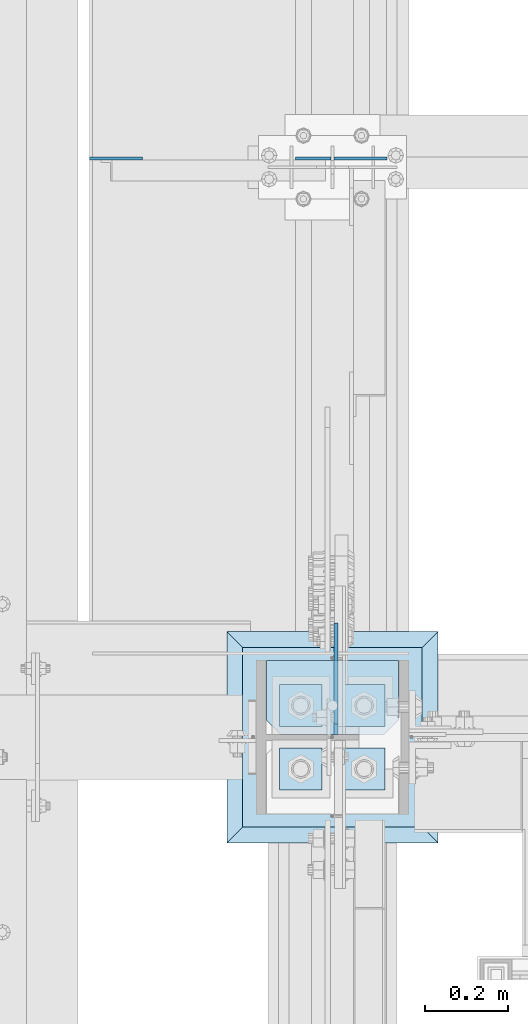
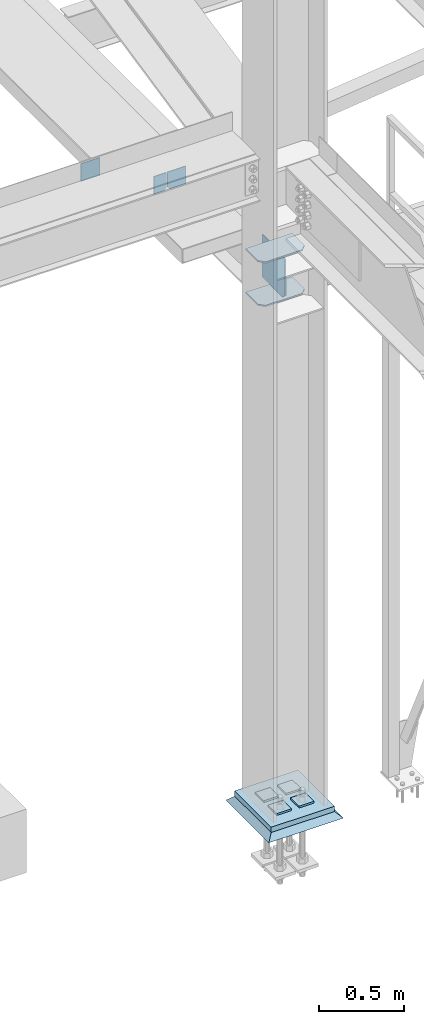
# One storey, part 3210 of 3843: 12 plates, 4 elements without a shape of their own.
"""IFC2X3 building model written with IfcOpenShell, lengths in millimetres."""

from ifc_helpers import new_model, si_unit, frame, origin_with_axes, place, context, subcontext, project, spatial, faceted_brep, material, type_object, element, aggregate, save


model = new_model("IFC2X3")

# Units and contexts
model_context = context("Model", 3, precision=1e-05, world=origin_with_axes())
body_context = subcontext(model_context, "Body", "Model", "MODEL_VIEW")
ifc_project = project(units=[si_unit("LENGTHUNIT", "METRE", prefix="MILLI"), si_unit("AREAUNIT", "SQUARE_METRE"), si_unit("VOLUMEUNIT", "CUBIC_METRE"), si_unit("MASSUNIT", "GRAM", prefix="KILO"), si_unit("TIMEUNIT", "SECOND"), si_unit("PLANEANGLEUNIT", "RADIAN"), si_unit("SOLIDANGLEUNIT", "STERADIAN"), si_unit("THERMODYNAMICTEMPERATUREUNIT", "DEGREE_CELSIUS"), si_unit("LUMINOUSINTENSITYUNIT", "LUMEN")], contexts=[model_context])

# Site, building, storey
site_placement = place(None, origin_with_axes())
site = spatial("IfcSite", under=ifc_project, at=site_placement, CompositionType="ELEMENT")
building_placement = place(site_placement, origin_with_axes())
building = spatial("IfcBuilding", under=site, at=building_placement, Name="Undefined", CompositionType="ELEMENT")
storey_placement = place(building_placement, origin_with_axes())
storey = spatial("IfcBuildingStorey", under=building, at=storey_placement, Name="Undefined", CompositionType="ELEMENT", Elevation=0.0)

# Assembly, plates
assembly_1_placement = place(storey_placement, origin_with_axes())
assembly_1 = element("IfcElementAssembly", 1, at=assembly_1_placement, inside=storey, Name="BEAM", AssemblyPlace="NOTDEFINED", PredefinedType="RIGID_FRAME")
ifc_material_1 = material(Name="STEEL/A572-50")
plate_type_1 = type_object("IfcPlateType", PredefinedType="NOTDEFINED")
plate_1_placement = place(assembly_1_placement, frame((36579.96875, 35238.332812, 33769.3), z_axis=(0.0, 0.0, -1.0), x_axis=(1.0, 0.0, 0.0)))
plate_1 = element("IfcPlate", 2, at=plate_1_placement, type_object=plate_type_1, material=ifc_material_1, Name="PLATE", context=body_context, shape_type="Brep", body=[
    faceted_brep([(0.0, -3.17499999999927, 0.0), (0.0, -3.17500000000291, 107.950000000004), (0.0, 3.17500000000291, 107.950000000004), (0.0, 3.17499999999927, 0.0), (19.0500000000029, -3.17500000000291, 127.0), (19.0500000000029, 3.17500000000291, 127.0), (127.0, -3.17500000000291, 127.0), (127.0, 3.17500000000291, 127.0), (127.0, -3.17500000000291, 0.0), (127.0, 3.17500000000291, 0.0)], [[[0, 1, 2, 3]], [[1, 4, 5, 2]], [[4, 6, 7, 5]], [[6, 8, 9, 7]], [[8, 0, 3, 9]], [[5, 7, 9, 3, 2]], [[8, 6, 4, 1, 0]]]),
])
plate_2_placement = place(assembly_1_placement, frame((35991.8000305176, 35238.3328120001, 33909.0000061035), z_axis=(0.0, 0.0, 1.0), x_axis=(1.0, 0.0, 0.0)))
plate_2 = element("IfcPlate", 3, at=plate_2_placement, type_object=plate_type_1, material=ifc_material_1, Name="PLATE", context=body_context, shape_type="Brep", body=[
    faceted_brep([(0.0, -3.17499999999927, 0.0), (-6.10351708019152e-06, -3.17500000000291, 126.999993896483), (-6.10351708019152e-06, 3.17500000000291, 126.999993896483), (0.0, 3.17499999999927, 0.0), (127.0, -3.17500000000291, 127.0), (127.0, 3.17500000000291, 127.0), (127.0, -3.17500000000291, 0.0), (127.0, 3.17500000000291, 0.0)], [[[0, 1, 2, 3]], [[1, 4, 5, 2]], [[4, 6, 7, 5]], [[6, 0, 3, 7]], [[5, 7, 3, 2]], [[6, 4, 1, 0]]]),
])
plate_type_2 = type_object("IfcPlateType", PredefinedType="NOTDEFINED")
plate_3_placement = place(assembly_1_placement, frame((36572.0312591215, 35238.332812, 33769.3), z_axis=(0.0, 0.0, -1.0), x_axis=(-1.0, 0.0, 0.0)))
plate_3 = element("IfcPlate", 4, at=plate_3_placement, type_object=plate_type_2, material=ifc_material_1, Name="PLATE", context=body_context, shape_type="Brep", body=[
    faceted_brep([(0.0, -3.17499999999927, 0.0), (0.0, -3.17500000000291, 107.950000000004), (0.0, 3.17500000000291, 107.950000000004), (0.0, 3.17499999999927, 0.0), (19.0500000000029, -3.17500000000291, 127.0), (19.0500000000029, 3.17500000000291, 127.0), (84.9312591264534, -3.17500000000291, 126.999993896701), (84.9312591264534, 3.17500000000291, 126.999993896701), (84.9312500000015, -3.17500000000291, 2.18278728425503e-10), (84.9312500000015, 3.17500000000291, 2.18278728425503e-10)], [[[0, 1, 2, 3]], [[1, 4, 5, 2]], [[4, 6, 7, 5]], [[6, 8, 9, 7]], [[8, 0, 3, 9]], [[5, 7, 9, 3, 2]], [[8, 6, 4, 1, 0]]]),
])
aggregate(assembly_1, [plate_1, plate_3, plate_2])

assembly_2_placement = place(storey_placement, origin_with_axes())
assembly_2 = element("IfcElementAssembly", 5, at=assembly_2_placement, inside=storey, Name="COLUMN", AssemblyPlace="NOTDEFINED", PredefinedType="RIGID_FRAME")
plate_type_3 = type_object("IfcPlateType", PredefinedType="NOTDEFINED")
plate_4_placement = place(assembly_2_placement, frame((36734.75, 34030.44375, 33688.3375), z_axis=(-1.0, 0.0, 0.0), x_axis=(0.0, -1.0, 0.0)))
plate_4 = element("IfcPlate", 6, at=plate_4_placement, type_object=plate_type_3, material=ifc_material_1, Name="PLATE", context=body_context, shape_type="Brep", body=[
    faceted_brep([(0.0, -4.76249999999709, 0.0), (0.0, -4.76249999785796, 317.500000005042), (0.0, 4.76250000210712, 317.50000000505), (0.0, 4.76249999999709, 0.0), (144.462501525879, -4.76249999999709, 317.5), (144.462501525879, 4.76249999999709, 317.5), (177.800003051758, -4.76249999999709, 284.162498474121), (177.800003051758, 4.76249999999709, 284.162498474121), (177.800003051758, -4.76249999999709, 33.3375015258789), (177.800003051758, 4.76249999999709, 33.3375015258789), (144.462501525879, -4.76249999999709, 0.0), (144.462501525879, 4.76249999999709, 0.0)], [[[0, 1, 2, 3]], [[1, 4, 5, 2]], [[4, 6, 7, 5]], [[6, 8, 9, 7]], [[8, 10, 11, 9]], [[10, 0, 3, 11]], [[5, 7, 9, 11, 3, 2]], [[10, 8, 6, 4, 1, 0]]]),
])
plate_5_placement = place(assembly_2_placement, frame((36734.75, 34030.44375, 34002.6625), z_axis=(-1.0, 0.0, 0.0), x_axis=(0.0, -1.0, 0.0)))
plate_5 = element("IfcPlate", 7, at=plate_5_placement, type_object=plate_type_3, material=ifc_material_1, Name="PLATE", context=body_context, shape_type="Brep", body=[
    faceted_brep([(0.0, -4.76249999999709, 0.0), (0.0, -4.76249999785796, 317.500000005042), (0.0, 4.76250000210712, 317.50000000505), (0.0, 4.76249999999709, 0.0), (144.462501525879, -4.76249999999709, 317.5), (144.462501525879, 4.76249999999709, 317.5), (177.800003051758, -4.76249999999709, 284.162498474121), (177.800003051758, 4.76249999999709, 284.162498474121), (177.800003051758, -4.76249999999709, 33.3375015258789), (177.800003051758, 4.76249999999709, 33.3375015258789), (144.462501525879, -4.76249999999709, 0.0), (144.462501525879, 4.76249999999709, 0.0)], [[[0, 1, 2, 3]], [[1, 4, 5, 2]], [[4, 6, 7, 5]], [[6, 8, 9, 7]], [[8, 10, 11, 9]], [[10, 0, 3, 11]], [[5, 7, 9, 11, 3, 2]], [[10, 8, 6, 4, 1, 0]]]),
])

assembly_3_placement = place(storey_placement, origin_with_axes())
assembly_3 = element("IfcElementAssembly", 8, at=assembly_3_placement, inside=storey, Name="TEMPLATE", AssemblyPlace="NOTDEFINED", PredefinedType="RIGID_FRAME")
plate_type_4 = type_object("IfcPlateType", PredefinedType="NOTDEFINED")
plate_6_placement = place(assembly_3_placement, frame((36601.4, 33820.1, 30105.35), z_axis=(0.0, -1.0, 0.0), x_axis=(1.0, 0.0, 0.0)))
plate_6 = element("IfcPlate", 9, at=plate_6_placement, type_object=plate_type_4, material=ifc_material_1, Name="Washer Plate", context=body_context, shape_type="Brep", body=[
    faceted_brep([(0.0, -6.3499999046162, 0.0), (-1.67347025126219e-10, -6.35000000000582, 101.600000000151), (-1.67347025126219e-10, 6.35000000000582, 101.600000000151), (7.27595761418343e-12, 6.3499999046162, 0.0), (101.599998474121, -6.34999999999854, 101.599998474121), (101.599998474121, 6.34999999999854, 101.599998474121), (101.6, -6.34999999999854, 0.0), (101.6, 6.34999999999854, 0.0)], [[[0, 1, 2, 3]], [[1, 4, 5, 2]], [[4, 6, 7, 5]], [[6, 0, 3, 7]], [[5, 7, 3, 2]], [[6, 4, 1, 0]]]),
])
plate_7_placement = place(assembly_3_placement, frame((36601.4, 33972.5, 30105.35), z_axis=(0.0, -1.0, 0.0), x_axis=(1.0, 0.0, 0.0)))
plate_7 = element("IfcPlate", 10, at=plate_7_placement, type_object=plate_type_4, material=ifc_material_1, Name="Washer Plate", context=body_context, shape_type="Brep", body=[
    faceted_brep([(0.0, -6.3499999046162, 0.0), (-1.67347025126219e-10, -6.35000000000582, 101.600000000151), (-1.67347025126219e-10, 6.35000000000582, 101.600000000151), (7.27595761418343e-12, 6.3499999046162, 0.0), (101.599998474121, -6.34999999999854, 101.599998474121), (101.599998474121, 6.34999999999854, 101.599998474121), (101.6, -6.34999999999854, 0.0), (101.6, 6.34999999999854, 0.0)], [[[0, 1, 2, 3]], [[1, 4, 5, 2]], [[4, 6, 7, 5]], [[6, 0, 3, 7]], [[5, 7, 3, 2]], [[6, 4, 1, 0]]]),
])
plate_8_placement = place(assembly_3_placement, frame((36449.0, 33820.1, 30105.35), z_axis=(0.0, -1.0, 0.0), x_axis=(1.0, 0.0, 0.0)))
plate_8 = element("IfcPlate", 11, at=plate_8_placement, type_object=plate_type_4, material=ifc_material_1, Name="Washer Plate", context=body_context, shape_type="Brep", body=[
    faceted_brep([(0.0, -6.3499999046162, 0.0), (-1.67347025126219e-10, -6.35000000000582, 101.600000000151), (-1.67347025126219e-10, 6.35000000000582, 101.600000000151), (7.27595761418343e-12, 6.3499999046162, 0.0), (101.599998474121, -6.34999999999854, 101.599998474121), (101.599998474121, 6.34999999999854, 101.599998474121), (101.6, -6.34999999999854, 0.0), (101.6, 6.34999999999854, 0.0)], [[[0, 1, 2, 3]], [[1, 4, 5, 2]], [[4, 6, 7, 5]], [[6, 0, 3, 7]], [[5, 7, 3, 2]], [[6, 4, 1, 0]]]),
])
plate_9_placement = place(assembly_3_placement, frame((36449.0, 33972.5, 30105.35), z_axis=(0.0, -1.0, 0.0), x_axis=(1.0, 0.0, 0.0)))
plate_9 = element("IfcPlate", 12, at=plate_9_placement, type_object=plate_type_4, material=ifc_material_1, Name="Washer Plate", context=body_context, shape_type="Brep", body=[
    faceted_brep([(0.0, -6.3499999046162, 0.0), (-1.67347025126219e-10, -6.35000000000582, 101.600000000151), (-1.67347025126219e-10, 6.35000000000582, 101.600000000151), (7.27595761418343e-12, 6.3499999046162, 0.0), (101.599998474121, -6.34999999999854, 101.599998474121), (101.599998474121, 6.34999999999854, 101.599998474121), (101.6, -6.34999999999854, 0.0), (101.6, 6.34999999999854, 0.0)], [[[0, 1, 2, 3]], [[1, 4, 5, 2]], [[4, 6, 7, 5]], [[6, 0, 3, 7]], [[5, 7, 3, 2]], [[6, 4, 1, 0]]]),
])
aggregate(assembly_3, [plate_6, plate_7, plate_8, plate_9])

# Plate
plate_type_5 = type_object("IfcPlateType", PredefinedType="NOTDEFINED")
plate_10_placement = place(assembly_2_placement, frame((36584.73125, 33852.64375, 33718.5000026613), z_axis=(0.0, 0.707106781186548, 0.707106781186548), x_axis=(5.70000238222118e-08, 0.707106781186546, -0.707106781186546)))
plate_10 = element("IfcPlate", 13, at=plate_10_placement, type_object=plate_type_5, material=ifc_material_1, Name="PLATE", context=body_context, shape_type="Brep", body=[
    faceted_brep([(0.0, -4.76249999999709, 0.0), (-179.605123758887, -4.76249999999709, 179.605121082153), (-179.605123758887, 4.76249999999709, 179.605121082153), (0.0, 4.76249999999709, 0.0), (-179.605123758927, -4.76249999999709, 215.526145298623), (-179.605123758927, 4.76249999999709, 215.526145298623), (-8.41899011431451, -4.76250000000073, 386.712279211657), (-8.41899011431451, 4.76250000000073, 386.712279211657), (207.107160643502, -4.76249999999709, 171.186135214331), (207.107160643502, 4.76249999999709, 171.186135214331), (35.9210247517349, -4.76249999999709, 1.30967237055302e-10), (35.9210247517349, 4.76249999999709, 1.30967237055302e-10)], [[[0, 1, 2, 3]], [[1, 4, 5, 2]], [[4, 6, 7, 5]], [[6, 8, 9, 7]], [[8, 10, 11, 9]], [[10, 0, 3, 11]], [[5, 7, 9, 11, 3, 2]], [[10, 8, 6, 4, 1, 0]]]),
])

plate_type_6 = type_object("IfcPlateType", PredefinedType="NOTDEFINED")
plate_11_placement = place(assembly_2_placement, frame((36360.1, 33629.6, 30079.95), z_axis=(0.0, 1.0, 0.0), x_axis=(1.0, 0.0, 0.0)))
plate_11 = element("IfcPlate", 14, at=plate_11_placement, type_object=plate_type_6, material=ifc_material_1, Name="PLATE", context=body_context, shape_type="Brep", body=[
    faceted_brep([(0.0, -19.0500000000029, 0.0), (0.0, -19.0499999999993, 431.799987792969), (0.0, 19.0499999999993, 431.799987792969), (0.0, 19.0500000000029, 0.0), (431.799987792969, -19.0499999999993, 431.799987792969), (431.799987792969, 19.0499999999993, 431.799987792969), (431.799957275391, -19.0499999999993, 0.0), (431.799957275391, 19.0499999999993, 0.0)], [[[0, 1, 2, 3]], [[1, 4, 5, 2]], [[4, 6, 7, 5]], [[6, 0, 3, 7]], [[5, 7, 3, 2]], [[6, 4, 1, 0]]]),
])

aggregate(assembly_2, [plate_4, plate_5, plate_10, plate_11])

# Assembly, plate
assembly_4_placement = place(storey_placement, origin_with_axes())
assembly_4 = element("IfcElementAssembly", 15, at=assembly_4_placement, inside=storey, Name="GROUT", AssemblyPlace="NOTDEFINED", PredefinedType="REINFORCEMENT_UNIT")
ifc_material_2 = material(Name="CONCRETE/Concrete_Undefined")
plate_type_7 = type_object("IfcPlateType", PredefinedType="NOTDEFINED")
plate_12_placement = place(assembly_4_placement, frame((36322.0, 33591.5, 30041.85), z_axis=(0.0, 1.0, 0.0), x_axis=(1.0, 0.0, 0.0)))
plate_12 = element("IfcPlate", 16, at=plate_12_placement, type_object=plate_type_7, material=ifc_material_2, Name="GROUT", context=body_context, shape_type="Brep", body=[
    faceted_brep([(38.1000000007043, -19.0499999997883, 469.899999999314), (0.0, 19.0499999999993, 508.0), (0.0, 19.0500000000029, 0.0), (38.1000000006916, -19.0499999999811, 38.1000000006607), (469.899999999325, -19.0499999998174, 38.1000000006607), (508.0, 19.0499999999993, 0.0), (508.0, 19.0499999999993, 508.0), (469.899999999325, -19.0499999999847, 469.899999999314)], [[[0, 1, 2, 3]], [[4, 5, 6, 7]], [[4, 7, 0, 3]], [[5, 4, 3, 2]], [[6, 5, 2, 1]], [[7, 6, 1, 0]]]),
])
aggregate(assembly_4, [plate_12])

save(model, "model.ifc")
